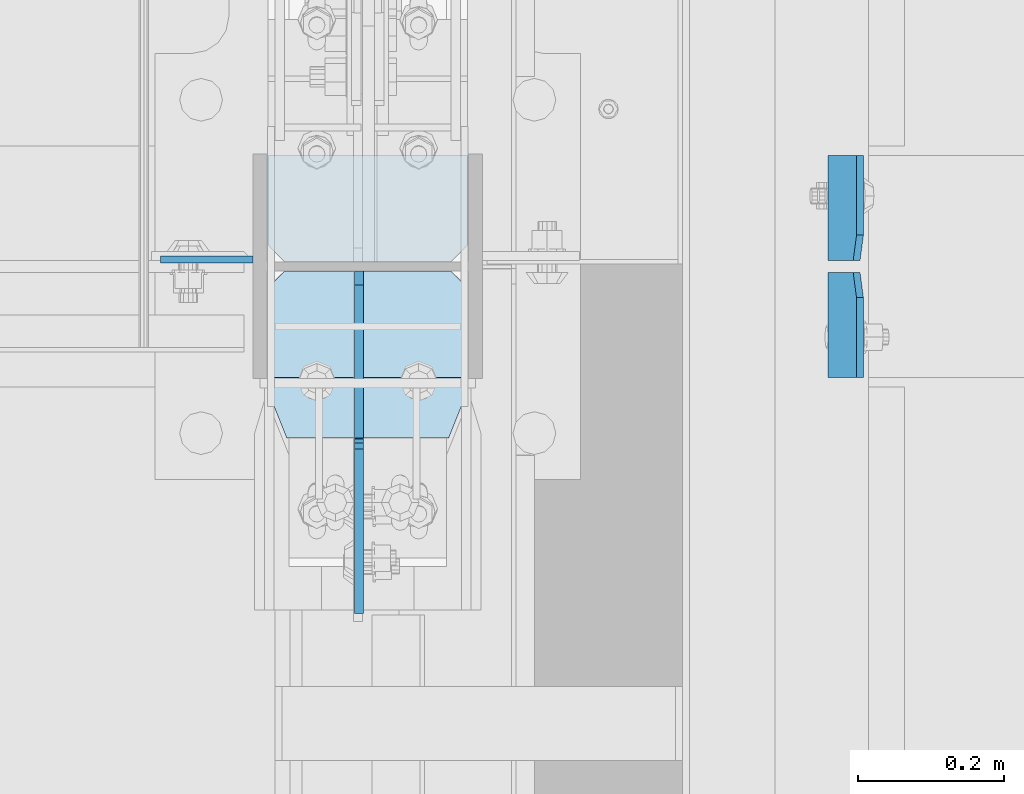
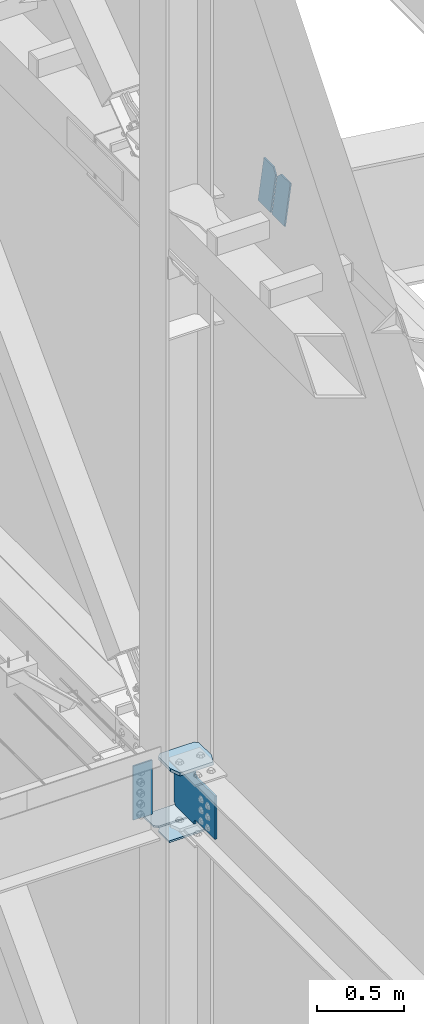
# One storey, part 1007 of 1179: 7 plates, 2 elements without a shape of their own.
"""IFC2X3 building model written with IfcOpenShell, lengths in millimetres."""

from ifc_helpers import new_model, si_unit, frame, origin_with_axes, place, context, subcontext, project, spatial, faceted_brep, material, type_object, element, aggregate, save


model = new_model("IFC2X3")

# Units and contexts
model_context = context("Model", 3, precision=1e-05, world=origin_with_axes())
body_context = subcontext(model_context, "Body", "Model", "MODEL_VIEW")
ifc_project = project(units=[si_unit("LENGTHUNIT", "METRE", prefix="MILLI"), si_unit("AREAUNIT", "SQUARE_METRE"), si_unit("VOLUMEUNIT", "CUBIC_METRE"), si_unit("MASSUNIT", "GRAM", prefix="KILO"), si_unit("TIMEUNIT", "SECOND"), si_unit("PLANEANGLEUNIT", "RADIAN"), si_unit("SOLIDANGLEUNIT", "STERADIAN"), si_unit("THERMODYNAMICTEMPERATUREUNIT", "DEGREE_CELSIUS"), si_unit("LUMINOUSINTENSITYUNIT", "LUMEN")], contexts=[model_context])

# Site, building, storey
site_placement = place(None, origin_with_axes())
site = spatial("IfcSite", under=ifc_project, at=site_placement, CompositionType="ELEMENT")
building_placement = place(site_placement, origin_with_axes())
building = spatial("IfcBuilding", under=site, at=building_placement, Name="Undefined", CompositionType="ELEMENT")
storey_placement = place(building_placement, origin_with_axes())
storey = spatial("IfcBuildingStorey", under=building, at=storey_placement, Name="Undefined", CompositionType="ELEMENT", Elevation=0.0)

# Assembly, plate
assembly_1_placement = place(storey_placement, origin_with_axes())
assembly_1 = element("IfcElementAssembly", 1, at=assembly_1_placement, inside=storey, Name="COLUMN", AssemblyPlace="NOTDEFINED", PredefinedType="RIGID_FRAME")
ifc_material_1 = material(Name="STEEL/A36")
plate_type_1 = type_object("IfcPlateType", PredefinedType="NOTDEFINED")
plate_1_placement = place(assembly_1_placement, frame((24150.6375, 11490.325, 4064.0), z_axis=(-1.0, 0.0, 0.0), x_axis=(0.0, 0.0, -1.0)))
plate_1 = element("IfcPlate", 2, at=plate_1_placement, type_object=plate_type_1, material=ifc_material_1, Name="PLATE", context=body_context, shape_type="Brep", body=[
    faceted_brep([(0.0, -4.76249999999709, 0.0), (0.0, -4.76249999999709, 127.0), (0.0, 4.76249999999709, 127.0), (0.0, 4.76249999999709, 0.0), (381.0, -4.76249999999709, 127.0), (381.0, 4.76249999999709, 127.0), (381.0, -4.76249999999999, 8.66293703438714e-11), (381.0, 4.76249999999999, 8.66293703438714e-11)], [[[0, 1, 2, 3]], [[1, 4, 5, 2]], [[4, 6, 7, 5]], [[6, 0, 3, 7]], [[5, 7, 3, 2]], [[6, 4, 1, 0]]]),
])

# Assembly, plates
assembly_2_placement = place(storey_placement, origin_with_axes())
assembly_2 = element("IfcElementAssembly", 3, at=assembly_2_placement, inside=storey, Name="BEAM", AssemblyPlace="NOTDEFINED", PredefinedType="RIGID_FRAME")
plate_type_2 = type_object("IfcPlateType", PredefinedType="NOTDEFINED")
plate_2_placement = place(assembly_2_placement, frame((24982.9723149182, 11488.7375, 7924.64444971845), z_axis=(0.0, 1.0, 0.0), x_axis=(-0.133813222971046, 0.0, -0.991006569785539)))
plate_2 = element("IfcPlate", 4, at=plate_2_placement, type_object=plate_type_2, material=ifc_material_1, Name="PLATE", context=body_context, shape_type="Brep", body=[
    faceted_brep([(0.0, -4.76250000000073, 34.9249999999993), (0.0, -4.76249999999982, 144.462500000001), (0.0, 4.76249999999982, 144.462500000001), (0.0, 4.76250000000073, 34.9249999999993), (290.512500000299, -4.76249999965512, 144.4625), (290.512500000297, 4.76250000035361, 144.4625), (290.512500000297, -4.76249999966967, 0.0), (290.512500000294, 4.76250000033906, 0.0), (34.9249992370715, -4.76249999996799, 0.0), (34.9249992370678, 4.76250000003347, 0.0)], [[[0, 1, 2, 3]], [[1, 4, 5, 2]], [[4, 6, 7, 5]], [[6, 8, 9, 7]], [[8, 0, 3, 9]], [[5, 7, 9, 3, 2]], [[8, 6, 4, 1, 0]]]),
])
plate_3_placement = place(assembly_2_placement, frame((24982.9723149443, 11472.8625, 7924.64444967892), z_axis=(0.0, -1.0, 0.0), x_axis=(-0.133813222971046, 0.0, -0.991006569785539)))
plate_3 = element("IfcPlate", 5, at=plate_3_placement, type_object=plate_type_2, material=ifc_material_1, Name="PLATE", context=body_context, shape_type="Brep", body=[
    faceted_brep([(0.0, -4.76250000000073, 34.9249999999993), (0.0, -4.76249999999982, 144.462500000001), (0.0, 4.76249999999982, 144.462500000001), (0.0, 4.76250000000073, 34.9249999999993), (290.512500000299, -4.76249999965512, 144.4625), (290.512500000297, 4.76250000035361, 144.4625), (290.512500000297, -4.76249999966967, 0.0), (290.512500000294, 4.76250000033906, 0.0), (34.9249992370715, -4.76249999996799, 0.0), (34.9249992370678, 4.76250000003347, 0.0)], [[[0, 1, 2, 3]], [[1, 4, 5, 2]], [[4, 6, 7, 5]], [[6, 8, 9, 7]], [[8, 0, 3, 9]], [[5, 7, 9, 3, 2]], [[8, 6, 4, 1, 0]]]),
])
aggregate(assembly_2, [plate_2, plate_3])

# Plate
ifc_material_2 = material(Name="STEEL/A572-GR.50")
plate_type_3 = type_object("IfcPlateType", PredefinedType="NOTDEFINED")
plate_4_placement = place(assembly_1_placement, frame((24171.275, 11245.85, 4090.9875), z_axis=(1.0, 0.0, 0.0), x_axis=(0.0, 1.0, 0.0)))
plate_4 = element("IfcPlate", 6, at=plate_4_placement, type_object=plate_type_3, material=ifc_material_2, Name="PLATE", context=body_context, shape_type="Brep", body=[
    faceted_brep([(0.0, -11.1125000000002, 247.650000381473), (63.5, -11.1125000000002, 273.050000000003), (63.5, 11.1125000000002, 273.050000000003), (0.0, 11.1125000000002, 247.650000381473), (63.5, -11.1125000000002, 0.0), (0.0, -11.1125000000002, 25.3999996185303), (0.0, 11.1125000000002, 25.3999996185303), (63.5, 11.1125000000002, 0.0), (206.374999618529, -11.1125000000002, 0.0), (206.374999618529, 11.1125000000002, 0.0), (228.599999999999, -11.1125000000002, 22.2250003814697), (228.599999999999, 11.1125000000002, 22.2250003814697), (228.599999999999, -11.1125000000002, 250.824999618533), (228.599999999999, 11.1125000000002, 250.824999618533), (206.374999618529, -11.1125000000002, 273.050000000003), (206.374999618529, 11.1125000000002, 273.050000000003)], [[[0, 1, 2, 3]], [[4, 5, 6, 7]], [[8, 4, 7, 9]], [[10, 8, 9, 11]], [[12, 10, 11, 13]], [[14, 12, 13, 15]], [[4, 8, 10, 12, 14, 1, 0, 5]], [[5, 0, 3, 6]], [[2, 15, 13, 11, 9, 7, 6, 3]], [[1, 14, 15, 2]]]),
])

plate_type_4 = type_object("IfcPlateType", PredefinedType="NOTDEFINED")
plate_5_placement = place(assembly_1_placement, frame((24444.325, 11474.45, 3575.05), z_axis=(-1.0, 0.0, 0.0), x_axis=(0.0, -1.0, 0.0)))
plate_5 = element("IfcPlate", 7, at=plate_5_placement, type_object=plate_type_4, material=ifc_material_1, Name="PLATE", context=body_context, shape_type="Brep", body=[
    faceted_brep([(0.0, -6.34999999999854, 22.2250003814697), (0.0, -6.35000000000036, 250.82499961853), (0.0, 6.35000000000036, 250.82499961853), (0.0, 6.34999999999854, 22.2250003814697), (22.2250003814697, -6.35000000000036, 273.05), (22.2250003814697, 6.35000000000036, 273.05), (146.050003051758, -6.35000000000036, 273.049987792969), (146.050003051758, 6.35000000000036, 273.049987792969), (146.050003051758, -6.35000000000036, 0.0), (146.050003051758, 6.35000000000036, 0.0), (22.2250003814697, -6.34999999999854, 0.0), (22.2250003814697, 6.34999999999854, 0.0)], [[[0, 1, 2, 3]], [[1, 4, 5, 2]], [[4, 6, 7, 5]], [[6, 8, 9, 7]], [[8, 10, 11, 9]], [[10, 0, 3, 11]], [[5, 7, 9, 11, 3, 2]], [[10, 8, 6, 4, 1, 0]]]),
])

plate_6_placement = place(assembly_1_placement, frame((24444.325, 11633.2, 3575.05), z_axis=(-1.0, 0.0, 0.0), x_axis=(0.0, -1.0, 0.0)))
plate_6 = element("IfcPlate", 8, at=plate_6_placement, type_object=plate_type_4, material=ifc_material_1, Name="PLATE", context=body_context, shape_type="Brep", body=[
    faceted_brep([(0.0, -6.34999999999854, 0.0), (0.0, -6.34999999999991, 273.05), (0.0, 6.34999999999991, 273.05), (0.0, 6.34999999999854, 0.0), (123.824999618599, -6.34999999999991, 273.05), (123.824999618599, 6.34999999999991, 273.05), (146.050000000068, -6.34999999999991, 250.82499961853), (146.050000000068, 6.34999999999991, 250.82499961853), (146.050000000068, -6.34999999999991, 22.2250003814697), (146.050000000068, 6.34999999999991, 22.2250003814697), (123.824999618599, -6.34999999999991, 0.0), (123.824999618599, 6.34999999999991, 0.0)], [[[0, 1, 2, 3]], [[1, 4, 5, 2]], [[4, 6, 7, 5]], [[6, 8, 9, 7]], [[8, 10, 11, 9]], [[10, 0, 3, 11]], [[5, 7, 9, 11, 3, 2]], [[10, 8, 6, 4, 1, 0]]]),
])

plate_type_5 = type_object("IfcPlateType", PredefinedType="NOTDEFINED")
plate_7_placement = place(assembly_1_placement, frame((24295.89375, 11474.4499999529, 3727.4500034064), z_axis=(0.0, -0.707106781186506, 0.707106781186589), x_axis=(0.0, -0.70710678118659, -0.707106781186505)))
plate_7 = element("IfcPlate", 9, at=plate_7_placement, type_object=plate_type_5, material=ifc_material_2, Name="PLATE", context=body_context, shape_type="Brep", body=[
    faceted_brep([(0.0, -6.34999999999854, 0.0), (-235.731724934591, -6.35000000000002, 235.731721421089), (-235.731724934591, 6.35000000000002, 235.731721421089), (0.0, 6.34999999999854, 0.0), (-235.731724934656, -6.35000000000002, 262.67248958346), (-235.731724934656, 6.35000000000002, 262.67248958346), (-87.5574986365136, -6.35000000000002, 410.846713673389), (-87.5574986365136, 6.35000000000002, 410.846713673389), (-85.3124343197815, -6.35000000000002, 408.601649390112), (-85.3124343197815, 6.35000000000002, 408.601649390112), (-77.072081342445, -6.35000000000002, 403.095621650566), (-77.072081342445, 6.35000000000002, 403.095621650566), (-67.3519222919531, -6.35000000000002, 401.162161877812), (-67.3519222919531, 6.35000000000002, 401.162161877812), (-57.6317632702812, -6.35000000000002, 403.095621795397), (-57.6317632702812, 6.35000000000002, 403.095621795397), (-49.3914103750103, -6.35000000000002, 408.601649657729), (-49.3914103750103, 6.35000000000002, 408.601649657729), (103.272946260589, -6.35000000000002, 561.266008567964), (103.272946260589, 6.35000000000002, 561.266008567964), (318.799094772221, -6.35000000000002, 345.739863268682), (318.799094772221, 6.35000000000002, 345.739863268682), (166.134738136639, -6.35000000000002, 193.075504358469), (166.134738136639, 6.35000000000002, 193.075504358469), (160.628710397086, -6.35000000000002, 184.835151381158), (160.628710397086, 6.35000000000002, 184.835151381158), (158.695250624347, -6.35000000000002, 175.114992330684), (158.695250624347, 6.35000000000002, 175.114992330684), (160.628710541958, -6.35000000000002, 165.394833309019), (160.628710541958, 6.35000000000002, 165.394833309019), (166.134738404326, -6.35000000000002, 157.154480413748), (166.134738404326, 6.35000000000002, 157.154480413748), (175.114994360907, -6.34999999999854, 148.174225997692), (175.114994360907, 6.34999999999854, 148.174225997692), (26.9407683631471, -6.34999999999854, -6.91215973347425e-11), (26.9407683631471, 6.34999999999854, -6.91215973347425e-11)], [[[0, 1, 2, 3]], [[1, 4, 5, 2]], [[4, 6, 7, 5]], [[6, 8, 9, 7]], [[8, 10, 11, 9]], [[10, 12, 13, 11]], [[12, 14, 15, 13]], [[14, 16, 17, 15]], [[16, 18, 19, 17]], [[18, 20, 21, 19]], [[20, 22, 23, 21]], [[22, 24, 25, 23]], [[24, 26, 27, 25]], [[26, 28, 29, 27]], [[28, 30, 31, 29]], [[30, 32, 33, 31]], [[32, 34, 35, 33]], [[34, 0, 3, 35]], [[5, 7, 9, 11, 13, 15, 17, 19, 21, 23, 25, 27, 29, 31, 33, 35, 3, 2]], [[34, 32, 30, 28, 26, 24, 22, 20, 18, 16, 14, 12, 10, 8, 6, 4, 1, 0]]]),
])

aggregate(assembly_1, [plate_4, plate_7, plate_5, plate_6, plate_1])

save(model, "model.ifc")
